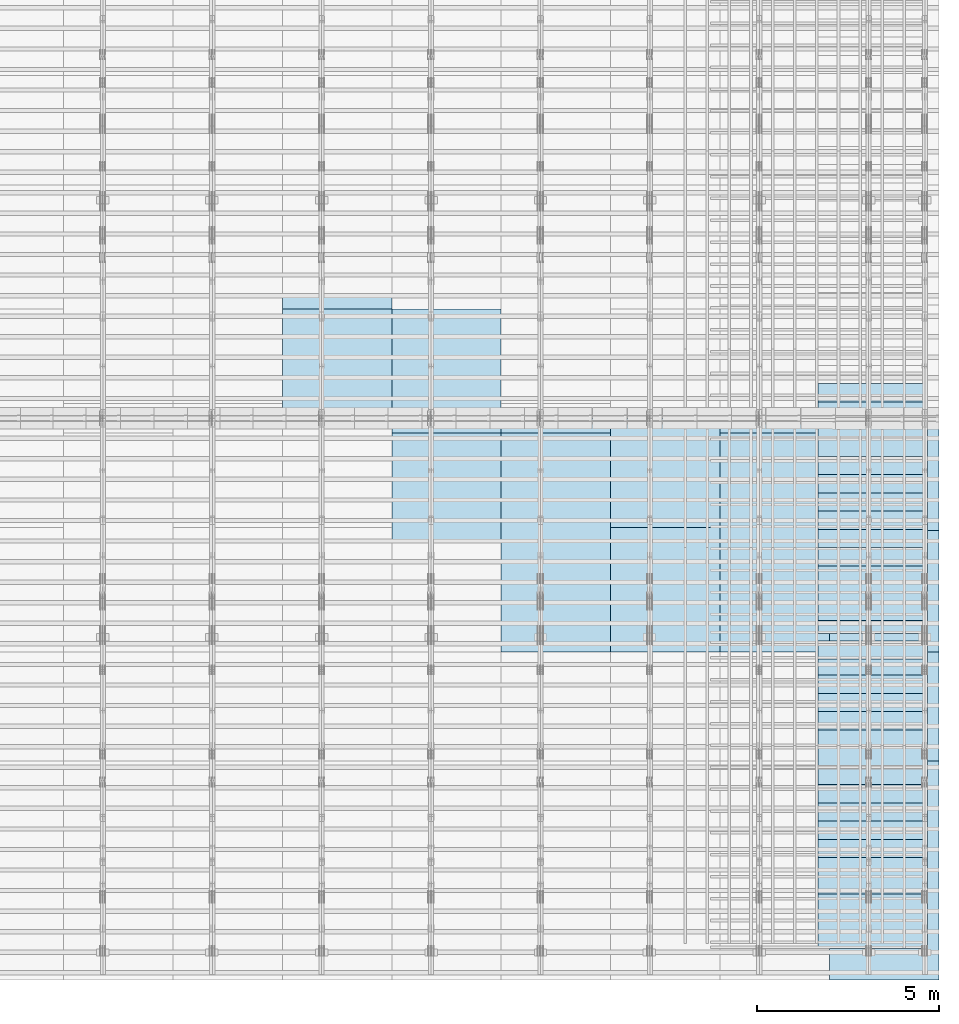
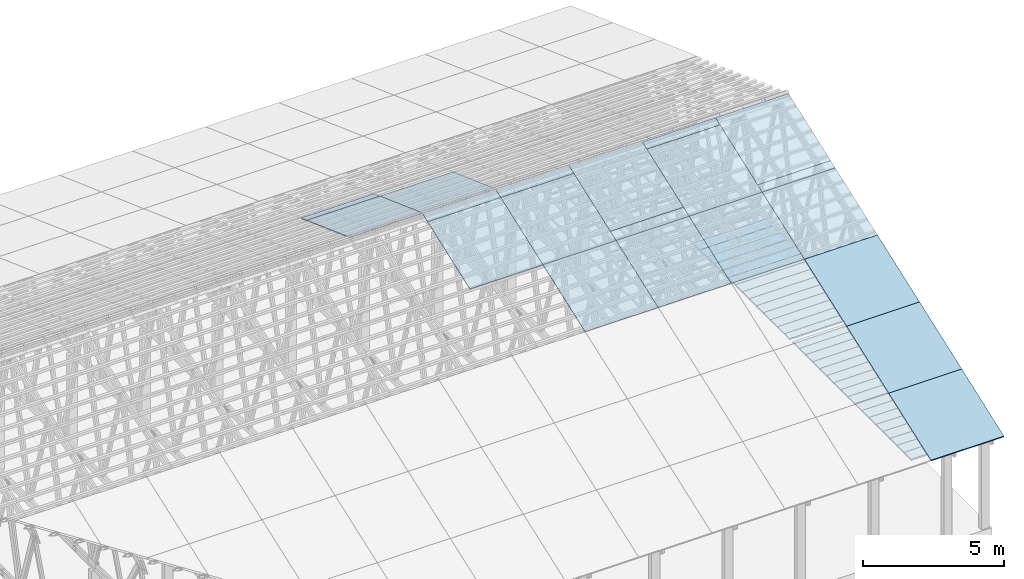
# One storey, part 9 of 189: 51 slabs, 51 elements without a shape of their own.
"""IFC2X3 building model written with IfcOpenShell, lengths in millimetres."""

import ifcopenshell
import ifcopenshell.guid

model = None  # the IFC model being written
_history = None  # IfcOwnerHistory: only IFC2X3 demands one
_inside = {}  # id of a spatial element -> (the spatial element, [elements in it])
_under = {}  # id of a project, library or spatial element -> (it, [spatial elements below it])
_declared = {}  # id of a project -> (the project, [libraries it declares])
_typed = {}  # id of a type object -> (the type object, [elements of that type])
_made_of = {}  # id of a material, layer set ... -> (it, [elements and type objects made of it])


def new_model(schema):
    """Start an empty IFC model of exactly this schema.

    Asked for "IFC4X3", IfcOpenShell would pick the latest addendum, in which some entities
    have other attributes; the version numbers below select the first issue.
    IFC2X3 requires an IfcOwnerHistory on every rooted entity: one is made here for all.
    """
    global model, _history
    if schema == "IFC4X3":
        model = ifcopenshell.file(schema_version=(4, 3, 0, 0))
    else:
        model = ifcopenshell.file(schema=schema)
    _inside.clear()
    _under.clear()
    _declared.clear()
    _typed.clear()
    _made_of.clear()
    _history = None
    if model.schema == "IFC2X3":
        org = make("IfcOrganization", Name="unknown")
        user = make(
            "IfcPersonAndOrganization",
            ThePerson=make("IfcPerson", FamilyName="unknown"),
            TheOrganization=org,
        )
        app = make(
            "IfcApplication",
            ApplicationDeveloper=org,
            Version="unknown",
            ApplicationFullName="unknown",
            ApplicationIdentifier="unknown",
        )
        _history = make(
            "IfcOwnerHistory",
            OwningUser=user,
            OwningApplication=app,
            ChangeAction="ADDED",
            CreationDate=0,
        )
    return model


def make(cls, **values):
    """One entity of the class cls with the attributes given. An attribute that is None is left unset."""
    return model.create_entity(
        cls, **{name: value for name, value in values.items() if value is not None}
    )


def entity(cls, *values):
    """Any entity or typed value of the class cls, its attributes in the order of the schema. None: left unset."""
    e = model.create_entity(cls)
    for i, value in enumerate(values):
        if value is not None:
            e[i] = value
    return e


def rooted(cls, **values):
    """An entity with a GlobalId (a new one), such as an element, a storey or a relation."""
    return make(cls, GlobalId=ifcopenshell.guid.new(), OwnerHistory=_history, **values)


def si_unit(unit_type, name, prefix=None):
    """IfcSIUnit, for example si_unit("LENGTHUNIT", "METRE", prefix="MILLI")."""
    return make("IfcSIUnit", UnitType=unit_type, Prefix=prefix, Name=name)


def converted_unit(unit_type, name, factor, base, dimensions=None, offset=None):
    """IfcConversionBasedUnit, such as the inch: factor (a typed value) times the base unit."""
    return make(
        "IfcConversionBasedUnit"
        if offset is None
        else "IfcConversionBasedUnitWithOffset",
        ConversionOffset=offset,
        Dimensions=None
        if dimensions is None
        else entity("IfcDimensionalExponents", *dimensions),
        UnitType=unit_type,
        Name=name,
        ConversionFactor=make(
            "IfcMeasureWithUnit", ValueComponent=factor, UnitComponent=base
        ),
    )


def derived_unit(unit_type, elements):
    """IfcDerivedUnit: a product of units, each with its exponent."""
    return make(
        "IfcDerivedUnit",
        Elements=[
            make("IfcDerivedUnitElement", Unit=unit, Exponent=power)
            for unit, power in elements
        ],
        UnitType=unit_type,
    )


def assignment(units):
    """IfcUnitAssignment: the units of a project."""
    return None if units is None else make("IfcUnitAssignment", Units=units)


def point(xyz):
    """IfcCartesianPoint."""
    return None if xyz is None else make("IfcCartesianPoint", Coordinates=xyz)


def direction(xyz):
    """IfcDirection."""
    return None if xyz is None else make("IfcDirection", DirectionRatios=xyz)


def frame(location, z_axis=None, x_axis=None):
    """IfcAxis2Placement3D, a coordinate frame: its origin and axes. An axis left out is left unset."""
    return make(
        "IfcAxis2Placement3D",
        Location=point(location),
        Axis=direction(z_axis),
        RefDirection=direction(x_axis),
    )


def frame_2d(location, x_axis=None):
    """IfcAxis2Placement2D, a coordinate frame in the plane: its origin and x axis."""
    return make(
        "IfcAxis2Placement2D", Location=point(location), RefDirection=direction(x_axis)
    )


def origin():
    """The frame at (0, 0, 0) with its axes left unset."""
    return frame((0.0, 0.0, 0.0))


def origin_2d_with_axis():
    """The frame at (0, 0) in the plane with the x axis (1, 0) written out."""
    return frame_2d((0.0, 0.0), x_axis=(1.0, 0.0))


def place(relative_to, where):
    """IfcLocalPlacement: puts the frame where relative to a parent placement (None: the world)."""
    return make(
        "IfcLocalPlacement", PlacementRelTo=relative_to, RelativePlacement=where
    )


def context(
    kind, dimensions, precision=None, world=None, true_north=None, identifier=None
):
    """IfcGeometricRepresentationContext, for example the 3D "Model" context."""
    return make(
        "IfcGeometricRepresentationContext",
        ContextIdentifier=identifier,
        ContextType=kind,
        CoordinateSpaceDimension=dimensions,
        Precision=precision,
        WorldCoordinateSystem=world,
        TrueNorth=true_north,
    )


def subcontext(parent, identifier, kind, view, scale=None):
    """IfcGeometricRepresentationSubContext, for example "Body" below "Model"."""
    return make(
        "IfcGeometricRepresentationSubContext",
        ContextIdentifier=identifier,
        ContextType=kind,
        ParentContext=parent,
        TargetScale=scale,
        TargetView=view,
    )


def project(units=None, contexts=None):
    """IfcProject with its units and contexts."""
    return rooted(
        "IfcProject",
        Name="project",
        RepresentationContexts=contexts,
        UnitsInContext=assignment(units),
    )


def spatial(cls, under=None, at=None, **own):
    """A site, building, storey or space (cls), placed at a placement, below another one or the project."""
    s = rooted(cls, ObjectPlacement=at, **own)
    if under is not None:
        _under.setdefault(under.id(), (under, []))[1].append(s)
    return s


def profile(cls, at=None, kind="AREA", **sizes):
    """A parametric profile (cls). Its sizes go by their IFC names, for example OverallWidth=200.0."""
    return make(cls, ProfileType=kind, Position=at, **sizes)


def rectangle(**sizes):
    """IfcRectangleProfileDef."""
    return profile("IfcRectangleProfileDef", **sizes)


def extrude(swept, where, along, depth):
    """IfcExtrudedAreaSolid: the profile swept, set in the frame where, extruded along a direction by depth."""
    return make(
        "IfcExtrudedAreaSolid",
        SweptArea=swept,
        Position=where,
        ExtrudedDirection=direction(along),
        Depth=depth,
    )


def shape(context_of_items, identifier, shape_type, items):
    """IfcShapeRepresentation: the items that make up one representation, for example the "Body"."""
    return make(
        "IfcShapeRepresentation",
        ContextOfItems=context_of_items,
        RepresentationIdentifier=identifier,
        RepresentationType=shape_type,
        Items=items,
    )


def material(Name=None, Category=None):
    """IfcMaterial."""
    return make("IfcMaterial", Name=Name, Category=Category)


def layer(
    of_material, thickness, ventilated=None, Name=None, Category=None, Priority=None
):
    """IfcMaterialLayer: one layer of a wall or slab, of a material (None: an air gap)."""
    return make(
        "IfcMaterialLayer",
        Material=of_material,
        LayerThickness=thickness,
        IsVentilated=ventilated,
        Name=Name,
        Category=Category,
        Priority=Priority,
    )


def layer_set(layers, Name=None):
    """IfcMaterialLayerSet."""
    return make("IfcMaterialLayerSet", MaterialLayers=layers, LayerSetName=Name)


def made_of(thing, what):
    """Note that an element or type object is made of a material, layer set ...; save() writes the relation."""
    if what is not None:
        _made_of.setdefault(what.id(), (what, []))[1].append(thing)
    return thing


def element(
    cls,
    number,
    at=None,
    inside=None,
    cuts=None,
    type_object=None,
    material=None,
    context=None,
    identifier="Body",
    shape_type=None,
    held_by="IfcProductDefinitionShape",
    body=None,
    shapes=None,
    **own,
):
    """One element of the class cls, such as IfcWall. Its Tag is "e" and its number.

    at: its placement. inside: the storey or other place that contains it. cuts: it is an
    opening in that element (IfcRelVoidsElement). A single representation is given by context,
    identifier, shape_type and body (its items); several are given by shapes. held_by: the class
    of the entity that holds the representations. save() writes the other relations.
    """
    e = rooted(cls, Tag="e%d" % number, ObjectPlacement=at, **own)
    if body is not None:
        shapes = [shape(context, identifier, shape_type, body)]
    if shapes is not None:
        e.Representation = make(held_by, Representations=shapes)
    if inside is not None:
        _inside.setdefault(inside.id(), (inside, []))[1].append(e)
    if cuts is not None:
        rooted(
            "IfcRelVoidsElement", RelatingBuildingElement=cuts, RelatedOpeningElement=e
        )
    if type_object is not None:
        _typed.setdefault(type_object.id(), (type_object, []))[1].append(e)
    return made_of(e, material)


def aggregate(whole, parts):
    """IfcRelAggregates: a whole, such as a stair, and the parts it consists of."""
    return rooted("IfcRelAggregates", RelatingObject=whole, RelatedObjects=parts)


def save(model, path):
    """Write the relations noted so far, then the file.

    IfcRelAggregates (storeys below a building ...), IfcRelContainedInSpatialStructure (elements
    in a storey), IfcRelDefinesByType, IfcRelAssociatesMaterial and IfcRelDeclares: one each for
    every whole, place, type object, material and project.
    """
    for whole, parts in _under.values():
        aggregate(whole, parts)
    for where, things in _inside.values():
        rooted(
            "IfcRelContainedInSpatialStructure",
            RelatedElements=things,
            RelatingStructure=where,
        )
    for kind, things in _typed.values():
        rooted("IfcRelDefinesByType", RelatedObjects=things, RelatingType=kind)
    for what, things in _made_of.values():
        rooted("IfcRelAssociatesMaterial", RelatedObjects=things, RelatingMaterial=what)
    for by, libraries in _declared.values():
        rooted("IfcRelDeclares", RelatingContext=by, RelatedDefinitions=libraries)
    model.write(path)


model = new_model("IFC2X3")

# Units and contexts
model_context = context("Model", 3, precision=0.01, world=origin(), true_north=direction((6.12303176911189e-17, 1.0)))
body_context = subcontext(model_context, "Body", "Model", "MODEL_VIEW")
ifc_project = project(units=[si_unit("LENGTHUNIT", "METRE", prefix="MILLI"), si_unit("AREAUNIT", "SQUARE_METRE"), si_unit("VOLUMEUNIT", "CUBIC_METRE"), converted_unit("PLANEANGLEUNIT", "DEGREE", entity("IfcRatioMeasure", 0.0174532925199433), si_unit("PLANEANGLEUNIT", "RADIAN"), dimensions=[0, 0, 0, 0, 0, 0, 0]), si_unit("MASSUNIT", "GRAM", prefix="KILO"), derived_unit("MASSDENSITYUNIT", [(si_unit("MASSUNIT", "GRAM", prefix="KILO"), 1), (si_unit("LENGTHUNIT", "METRE"), -3)]), si_unit("TIMEUNIT", "SECOND"), si_unit("FREQUENCYUNIT", "HERTZ"), si_unit("THERMODYNAMICTEMPERATUREUNIT", "DEGREE_CELSIUS"), derived_unit("THERMALTRANSMITTANCEUNIT", [(si_unit("MASSUNIT", "GRAM", prefix="KILO"), 1), (si_unit("THERMODYNAMICTEMPERATUREUNIT", "KELVIN"), -1), (si_unit("TIMEUNIT", "SECOND"), -3)]), derived_unit("VOLUMETRICFLOWRATEUNIT", [(si_unit("LENGTHUNIT", "METRE"), 3), (si_unit("TIMEUNIT", "SECOND"), -1)]), si_unit("ELECTRICCURRENTUNIT", "AMPERE"), si_unit("ELECTRICVOLTAGEUNIT", "VOLT"), si_unit("POWERUNIT", "WATT"), si_unit("FORCEUNIT", "NEWTON"), si_unit("ILLUMINANCEUNIT", "LUX"), si_unit("LUMINOUSFLUXUNIT", "LUMEN"), si_unit("LUMINOUSINTENSITYUNIT", "CANDELA"), derived_unit("USERDEFINED", [(si_unit("MASSUNIT", "GRAM", prefix="KILO"), -1), (si_unit("LENGTHUNIT", "METRE"), -2), (si_unit("TIMEUNIT", "SECOND"), 3), (si_unit("LUMINOUSFLUXUNIT", "LUMEN"), 1)]), derived_unit("LINEARVELOCITYUNIT", [(si_unit("LENGTHUNIT", "METRE"), 1), (si_unit("TIMEUNIT", "SECOND"), -1)]), si_unit("PRESSUREUNIT", "PASCAL"), derived_unit("USERDEFINED", [(si_unit("LENGTHUNIT", "METRE"), -2), (si_unit("MASSUNIT", "GRAM", prefix="KILO"), 1), (si_unit("TIMEUNIT", "SECOND"), -2)])], contexts=[model_context])

# Site, building, storey
site_placement = place(None, origin())
site = spatial("IfcSite", under=ifc_project, at=site_placement, CompositionType="ELEMENT")
building_placement = place(site_placement, origin())
building = spatial("IfcBuilding", under=site, at=building_placement, CompositionType="ELEMENT")
storey_placement = place(building_placement, origin())
storey = spatial("IfcBuildingStorey", under=building, at=storey_placement, Name="Default", CompositionType="ELEMENT", Elevation=0.0)

# Roof, slab
roof_1_placement = place(storey_placement, frame((47153.4200853154, -652.222549250825, 238.115215731819)))
roof_1 = element("IfcRoof", 1, at=roof_1_placement, inside=storey, ShapeType="NOTDEFINED")
ifc_material_1 = material()
ifc_layer_1 = layer(ifc_material_1, 40.0)
ifc_layer_set_1 = layer_set([ifc_layer_1])
slab_1_placement = place(roof_1_placement, origin())
slab_1 = element("IfcSlab", 2, at=slab_1_placement, material=ifc_layer_set_1, PredefinedType="ROOF", context=body_context, shape_type="SweptSolid", body=[
    extrude(rectangle(XDim=3192.53331742773, YDim=2999.99999999999, at=frame_2d((0.0, -3.41060513164848e-13), x_axis=(0.0, -1.0))), frame((1500.0, 1500.0, 545.955351399302), z_axis=(0.0, -0.342020143325668, 0.939692620785909), x_axis=(1.0, 0.0, 0.0)), (0.0, 0.342020143325668, 0.939692620785909), 42.5671108990364),
])
aggregate(roof_1, [slab_1])

roof_2_placement = place(building_placement, frame((47153.4200853155, 2347.77745074917, 1330.02591853042)))
roof_2 = element("IfcRoof", 3, at=roof_2_placement, inside=storey, ShapeType="NOTDEFINED")
slab_2_placement = place(roof_2_placement, origin())
slab_2 = element("IfcSlab", 4, at=slab_2_placement, material=ifc_layer_set_1, PredefinedType="ROOF", context=body_context, shape_type="SweptSolid", body=[
    extrude(rectangle(XDim=3192.53331742773, YDim=2999.99999999999, at=frame_2d((0.0, -1.13686837721616e-13), x_axis=(0.0, -1.0))), frame((1500.0, 1500.0, 545.955351399302), z_axis=(0.0, -0.342020143325668, 0.939692620785909), x_axis=(1.0, 0.0, 0.0)), (0.0, 0.342020143325668, 0.939692620785909), 42.5671108990353),
])
aggregate(roof_2, [slab_2])

roof_3_placement = place(building_placement, frame((47153.4200853155, 5347.77745074918, 2421.93662132902)))
roof_3 = element("IfcRoof", 5, at=roof_3_placement, inside=storey, ShapeType="NOTDEFINED")
slab_3_placement = place(roof_3_placement, origin())
slab_3 = element("IfcSlab", 6, at=slab_3_placement, material=ifc_layer_set_1, PredefinedType="ROOF", context=body_context, shape_type="SweptSolid", body=[
    extrude(rectangle(XDim=3192.53331742773, YDim=2999.99999999999, at=frame_2d((0.0, 0.0), x_axis=(0.0, -1.0))), frame((1500.0, 1500.0, 545.955351399302), z_axis=(0.0, -0.342020143325668, 0.939692620785909), x_axis=(1.0, 0.0, 0.0)), (0.0, 0.342020143325668, 0.939692620785909), 42.5671108990355),
])
aggregate(roof_3, [slab_3])

roof_4_placement = place(building_placement, frame((47153.4200853155, 8347.77745074918, 3513.84732412761)))
roof_4 = element("IfcRoof", 7, at=roof_4_placement, inside=storey, ShapeType="NOTDEFINED")
slab_4_placement = place(roof_4_placement, origin())
slab_4 = element("IfcSlab", 8, at=slab_4_placement, material=ifc_layer_set_1, PredefinedType="ROOF", context=body_context, shape_type="SweptSolid", body=[
    extrude(rectangle(XDim=3192.53331742773, YDim=2999.99999999999, at=frame_2d((0.0, 0.0), x_axis=(0.0, -1.0))), frame((1500.0, 1500.0, 545.955351399301), z_axis=(0.0, -0.342020143325668, 0.939692620785909), x_axis=(1.0, 0.0, 0.0)), (0.0, 0.342020143325668, 0.939692620785909), 42.5671108990366),
])
aggregate(roof_4, [slab_4])

roof_5_placement = place(building_placement, frame((47153.4200853155, 11347.7774507492, 4605.75802692621)))
roof_5 = element("IfcRoof", 9, at=roof_5_placement, inside=storey, ShapeType="NOTDEFINED")
slab_5_placement = place(roof_5_placement, origin())
slab_5 = element("IfcSlab", 10, at=slab_5_placement, material=ifc_layer_set_1, PredefinedType="ROOF", context=body_context, shape_type="SweptSolid", body=[
    extrude(rectangle(XDim=3192.53331742773, YDim=2999.99999999999, at=frame_2d((0.0, 0.0), x_axis=(0.0, -1.0))), frame((1500.0, 1500.0, 545.955351399303), z_axis=(0.0, -0.342020143325669, 0.939692620785908), x_axis=(1.0, 0.0, 0.0)), (0.0, 0.342020143325669, 0.939692620785908), 42.5671108990361),
])
aggregate(roof_5, [slab_5])

roof_6_placement = place(building_placement, frame((47153.4200853155, 11670.1261710963, 4723.08336618636)))
roof_6 = element("IfcRoof", 11, at=roof_6_placement, inside=storey, ShapeType="NOTDEFINED")
slab_6_placement = place(roof_6_placement, origin())
slab_6 = element("IfcSlab", 12, at=slab_6_placement, material=ifc_layer_set_1, PredefinedType="ROOF", context=body_context, shape_type="SweptSolid", body=[
    extrude(rectangle(XDim=3192.53331742773, YDim=2999.99999999999, at=frame_2d((0.0, 0.0), x_axis=(0.0, -1.0))), frame((1500.0, 1500.0, 545.955351399303), z_axis=(0.0, -0.342020143325669, 0.939692620785908), x_axis=(1.0, 0.0, 0.0)), (0.0, 0.342020143325669, 0.939692620785908), 42.5671108990372),
])
aggregate(roof_6, [slab_6])

roof_7_placement = place(storey_placement, frame((44153.4200853155, 8347.77745074919, 3513.84732412761)))
roof_7 = element("IfcRoof", 13, at=roof_7_placement, inside=storey, ShapeType="NOTDEFINED")
slab_7_placement = place(roof_7_placement, origin())
slab_7 = element("IfcSlab", 14, at=slab_7_placement, material=ifc_layer_set_1, PredefinedType="ROOF", context=body_context, shape_type="SweptSolid", body=[
    extrude(rectangle(XDim=3192.53331742773, YDim=2999.99999999999, at=frame_2d((0.0, 0.0), x_axis=(0.0, -1.0))), frame((1500.0, 1500.0, 545.955351399301), z_axis=(0.0, -0.342020143325668, 0.939692620785909), x_axis=(1.0, 0.0, 0.0)), (0.0, 0.342020143325668, 0.939692620785909), 42.5671108990366),
])
aggregate(roof_7, [slab_7])

roof_8_placement = place(storey_placement, frame((44153.4200853155, 11347.7774507492, 4605.75802692621)))
roof_8 = element("IfcRoof", 15, at=roof_8_placement, inside=storey, ShapeType="NOTDEFINED")
slab_8_placement = place(roof_8_placement, origin())
slab_8 = element("IfcSlab", 16, at=slab_8_placement, material=ifc_layer_set_1, PredefinedType="ROOF", context=body_context, shape_type="SweptSolid", body=[
    extrude(rectangle(XDim=3192.53331742773, YDim=2999.99999999999, at=frame_2d((0.0, 0.0), x_axis=(0.0, -1.0))), frame((1500.0, 1500.0, 545.955351399303), z_axis=(0.0, -0.342020143325669, 0.939692620785908), x_axis=(1.0, 0.0, 0.0)), (0.0, 0.342020143325669, 0.939692620785908), 42.5671108990361),
])
aggregate(roof_8, [slab_8])

roof_9_placement = place(storey_placement, frame((44153.4200853155, 11670.1261710963, 4723.08336618635)))
roof_9 = element("IfcRoof", 17, at=roof_9_placement, inside=storey, ShapeType="NOTDEFINED")
slab_9_placement = place(roof_9_placement, origin())
slab_9 = element("IfcSlab", 18, at=slab_9_placement, material=ifc_layer_set_1, PredefinedType="ROOF", context=body_context, shape_type="SweptSolid", body=[
    extrude(rectangle(XDim=3192.53331742773, YDim=2999.99999999999, at=frame_2d((0.0, 0.0), x_axis=(0.0, -1.0))), frame((1500.0, 1500.0, 545.955351399303), z_axis=(0.0, -0.342020143325669, 0.939692620785908), x_axis=(1.0, 0.0, 0.0)), (0.0, 0.342020143325669, 0.939692620785908), 42.5671108990372),
])
aggregate(roof_9, [slab_9])

roof_10_placement = place(storey_placement, frame((41153.4200853155, 8347.7774507492, 3513.84732412761)))
roof_10 = element("IfcRoof", 19, at=roof_10_placement, inside=storey, ShapeType="NOTDEFINED")
slab_10_placement = place(roof_10_placement, origin())
slab_10 = element("IfcSlab", 20, at=slab_10_placement, material=ifc_layer_set_1, PredefinedType="ROOF", context=body_context, shape_type="SweptSolid", body=[
    extrude(rectangle(XDim=3192.53331742773, YDim=2999.99999999999, at=frame_2d((0.0, 0.0), x_axis=(0.0, -1.0))), frame((1500.0, 1500.0, 545.955351399301), z_axis=(0.0, -0.342020143325668, 0.939692620785909), x_axis=(1.0, 0.0, 0.0)), (0.0, 0.342020143325668, 0.939692620785909), 42.5671108990366),
])
aggregate(roof_10, [slab_10])

roof_11_placement = place(storey_placement, frame((41153.4200853155, 11347.7774507492, 4605.75802692621)))
roof_11 = element("IfcRoof", 21, at=roof_11_placement, inside=storey, ShapeType="NOTDEFINED")
slab_11_placement = place(roof_11_placement, origin())
slab_11 = element("IfcSlab", 22, at=slab_11_placement, material=ifc_layer_set_1, PredefinedType="ROOF", context=body_context, shape_type="SweptSolid", body=[
    extrude(rectangle(XDim=3192.53331742773, YDim=2999.99999999999, at=frame_2d((0.0, 0.0), x_axis=(0.0, -1.0))), frame((1500.0, 1500.0, 545.955351399303), z_axis=(0.0, -0.342020143325669, 0.939692620785908), x_axis=(1.0, 0.0, 0.0)), (0.0, 0.342020143325669, 0.939692620785908), 42.5671108990361),
])
aggregate(roof_11, [slab_11])

roof_12_placement = place(storey_placement, frame((41153.4200853155, 11750.0000438631, 4752.15507836903)))
roof_12 = element("IfcRoof", 23, at=roof_12_placement, inside=storey, ShapeType="NOTDEFINED")
slab_12_placement = place(roof_12_placement, origin())
slab_12 = element("IfcSlab", 24, at=slab_12_placement, material=ifc_layer_set_1, PredefinedType="ROOF", context=body_context, shape_type="SweptSolid", body=[
    extrude(rectangle(XDim=3192.53331742773, YDim=2999.99999999999, at=frame_2d((0.0, 0.0), x_axis=(0.0, -1.0))), frame((1500.0, 1500.0, 545.955351399303), z_axis=(0.0, -0.342020143325669, 0.939692620785908), x_axis=(1.0, 0.0, 0.0)), (0.0, 0.342020143325669, 0.939692620785908), 42.5671108990361),
])
aggregate(roof_12, [slab_12])

roof_13_placement = place(storey_placement, frame((38153.4200853155, 8347.77745074921, 3513.84732412761)))
roof_13 = element("IfcRoof", 25, at=roof_13_placement, inside=storey, ShapeType="NOTDEFINED")
slab_13_placement = place(roof_13_placement, origin())
slab_13 = element("IfcSlab", 26, at=slab_13_placement, material=ifc_layer_set_1, PredefinedType="ROOF", context=body_context, shape_type="SweptSolid", body=[
    extrude(rectangle(XDim=3192.53331742773, YDim=2999.99999999999, at=frame_2d((0.0, 0.0), x_axis=(0.0, -1.0))), frame((1500.0, 1500.0, 545.955351399301), z_axis=(0.0, -0.342020143325668, 0.939692620785909), x_axis=(1.0, 0.0, 0.0)), (0.0, 0.342020143325668, 0.939692620785909), 42.5671108990366),
])
aggregate(roof_13, [slab_13])

roof_14_placement = place(storey_placement, frame((38153.4200853155, 11347.7774507492, 4605.75802692621)))
roof_14 = element("IfcRoof", 27, at=roof_14_placement, inside=storey, ShapeType="NOTDEFINED")
slab_14_placement = place(roof_14_placement, origin())
slab_14 = element("IfcSlab", 28, at=slab_14_placement, material=ifc_layer_set_1, PredefinedType="ROOF", context=body_context, shape_type="SweptSolid", body=[
    extrude(rectangle(XDim=3192.53331742773, YDim=2999.99999999999, at=frame_2d((0.0, 0.0), x_axis=(0.0, -1.0))), frame((1500.0, 1500.0, 545.955351399303), z_axis=(0.0, -0.342020143325669, 0.939692620785908), x_axis=(1.0, 0.0, 0.0)), (0.0, 0.342020143325669, 0.939692620785908), 42.5671108990361),
])
aggregate(roof_14, [slab_14])

roof_15_placement = place(storey_placement, frame((38153.4200853155, 11750.0000438631, 4752.15507836903)))
roof_15 = element("IfcRoof", 29, at=roof_15_placement, inside=storey, ShapeType="NOTDEFINED")
slab_15_placement = place(roof_15_placement, origin())
slab_15 = element("IfcSlab", 30, at=slab_15_placement, material=ifc_layer_set_1, PredefinedType="ROOF", context=body_context, shape_type="SweptSolid", body=[
    extrude(rectangle(XDim=3192.53331742773, YDim=2999.99999999999, at=frame_2d((0.0, 0.0), x_axis=(0.0, -1.0))), frame((1500.0, 1500.0, 545.955351399303), z_axis=(0.0, -0.342020143325669, 0.939692620785908), x_axis=(1.0, 0.0, 0.0)), (0.0, 0.342020143325669, 0.939692620785908), 42.5671108990361),
])
aggregate(roof_15, [slab_15])

roof_16_placement = place(storey_placement, frame((35153.4200853156, 11347.7774507492, 4605.75802692621)))
roof_16 = element("IfcRoof", 31, at=roof_16_placement, inside=storey, ShapeType="NOTDEFINED")
slab_16_placement = place(roof_16_placement, origin())
slab_16 = element("IfcSlab", 32, at=slab_16_placement, material=ifc_layer_set_1, PredefinedType="ROOF", context=body_context, shape_type="SweptSolid", body=[
    extrude(rectangle(XDim=3192.53331742773, YDim=2999.99999999999, at=frame_2d((0.0, 0.0), x_axis=(0.0, -1.0))), frame((1500.0, 1500.0, 545.955351399303), z_axis=(0.0, -0.342020143325669, 0.939692620785908), x_axis=(1.0, 0.0, 0.0)), (0.0, 0.342020143325669, 0.939692620785908), 42.5671108990361),
])
aggregate(roof_16, [slab_16])

roof_17_placement = place(storey_placement, frame((35153.4200853156, 11750.0000438631, 4752.15507836903)))
roof_17 = element("IfcRoof", 33, at=roof_17_placement, inside=storey, ShapeType="NOTDEFINED")
slab_17_placement = place(roof_17_placement, origin())
slab_17 = element("IfcSlab", 34, at=slab_17_placement, material=ifc_layer_set_1, PredefinedType="ROOF", context=body_context, shape_type="SweptSolid", body=[
    extrude(rectangle(XDim=3192.53331742773, YDim=2999.99999999999, at=frame_2d((0.0, 0.0), x_axis=(0.0, -1.0))), frame((1500.0, 1500.0, 545.955351399303), z_axis=(0.0, -0.342020143325669, 0.939692620785908), x_axis=(1.0, 0.0, 0.0)), (0.0, 0.342020143325669, 0.939692620785908), 42.5671108990361),
])
aggregate(roof_17, [slab_17])

roof_18_placement = place(storey_placement, frame((35153.4200853156, 14750.0000438631, 4752.15507836903)))
roof_18 = element("IfcRoof", 35, at=roof_18_placement, inside=storey, ShapeType="NOTDEFINED")
slab_18_placement = place(roof_18_placement, origin())
slab_18 = element("IfcSlab", 36, at=slab_18_placement, material=ifc_layer_set_1, PredefinedType="ROOF", context=body_context, shape_type="SweptSolid", body=[
    extrude(rectangle(XDim=3192.53331742773, YDim=3000.0, at=frame_2d((2.1600499167107e-12, -1.13686837721616e-13), x_axis=(0.0, 1.0))), frame((1500.0, 1500.0, 545.955351399304), z_axis=(0.0, 0.342020143325669, 0.939692620785908), x_axis=(1.0, 0.0, 0.0)), (0.0, -0.342020143325669, 0.939692620785908), 42.5671108990361),
])
aggregate(roof_18, [slab_18])

roof_19_placement = place(storey_placement, frame((32153.4200853156, 15152.222636977, 4605.75802692621)))
roof_19 = element("IfcRoof", 37, at=roof_19_placement, inside=storey, ShapeType="NOTDEFINED")
slab_19_placement = place(roof_19_placement, origin())
slab_19 = element("IfcSlab", 38, at=slab_19_placement, material=ifc_layer_set_1, PredefinedType="ROOF", context=body_context, shape_type="SweptSolid", body=[
    extrude(rectangle(XDim=3192.53331742773, YDim=3000.0, at=frame_2d((2.1600499167107e-12, -1.13686837721616e-13), x_axis=(0.0, 1.0))), frame((1500.0, 1500.0, 545.955351399304), z_axis=(0.0, 0.342020143325669, 0.939692620785908), x_axis=(1.0, 0.0, 0.0)), (0.0, -0.342020143325669, 0.939692620785908), 42.5671108990361),
])
aggregate(roof_19, [slab_19])

roof_20_placement = place(storey_placement, frame((32153.4200853156, 14750.0000438631, 4752.15507836903)))
roof_20 = element("IfcRoof", 39, at=roof_20_placement, inside=storey, ShapeType="NOTDEFINED")
slab_20_placement = place(roof_20_placement, origin())
slab_20 = element("IfcSlab", 40, at=slab_20_placement, material=ifc_layer_set_1, PredefinedType="ROOF", context=body_context, shape_type="SweptSolid", body=[
    extrude(rectangle(XDim=3192.53331742773, YDim=3000.0, at=frame_2d((2.1600499167107e-12, -1.13686837721616e-13), x_axis=(0.0, 1.0))), frame((1500.0, 1500.0, 545.955351399304), z_axis=(0.0, 0.342020143325669, 0.939692620785908), x_axis=(1.0, 0.0, 0.0)), (0.0, -0.342020143325669, 0.939692620785908), 42.5671108990361),
])
aggregate(roof_20, [slab_20])

roof_21_placement = place(storey_placement, frame((46837.7477027694, 205.0, -150.0)))
roof_21 = element("IfcRoof", 41, at=roof_21_placement, inside=storey, ShapeType="NOTDEFINED")
ifc_material_2 = material(Name="NLRS_n7_isolatie MegaPlus_Kingspan")
ifc_layer_2 = layer(ifc_material_2, 60.0)
ifc_layer_set_2 = layer_set([ifc_layer_2])
slab_21_placement = place(roof_21_placement, origin())
slab_21 = element("IfcSlab", 42, at=slab_21_placement, material=ifc_layer_set_2, PredefinedType="ROOF", context=body_context, shape_type="SweptSolid", body=[
    extrude(rectangle(XDim=3000.00000000001, YDim=499.99999999999, at=origin_2d_with_axis()), frame((1500.0, 250.0, 0.0)), (0.0, 0.0, 1.0), 60.0),
])
aggregate(roof_21, [slab_21])

roof_22_placement = place(storey_placement, frame((46837.7477027694, 705.0, -150.0)))
roof_22 = element("IfcRoof", 43, at=roof_22_placement, inside=storey, ShapeType="NOTDEFINED")
slab_22_placement = place(roof_22_placement, origin())
slab_22 = element("IfcSlab", 44, at=slab_22_placement, material=ifc_layer_set_2, PredefinedType="ROOF", context=body_context, shape_type="SweptSolid", body=[
    extrude(rectangle(XDim=3000.00000000001, YDim=499.99999999999, at=origin_2d_with_axis()), frame((1500.0, 250.0, 0.0)), (0.0, 0.0, 1.0), 60.0),
])
aggregate(roof_22, [slab_22])

roof_23_placement = place(storey_placement, frame((46837.7477027694, 1205.0, -150.0)))
roof_23 = element("IfcRoof", 45, at=roof_23_placement, inside=storey, ShapeType="NOTDEFINED")
slab_23_placement = place(roof_23_placement, origin())
slab_23 = element("IfcSlab", 46, at=slab_23_placement, material=ifc_layer_set_2, PredefinedType="ROOF", context=body_context, shape_type="SweptSolid", body=[
    extrude(rectangle(XDim=3000.00000000001, YDim=499.99999999999, at=origin_2d_with_axis()), frame((1500.0, 250.0, 0.0)), (0.0, 0.0, 1.0), 60.0),
])
aggregate(roof_23, [slab_23])

roof_24_placement = place(storey_placement, frame((46837.7477027694, 1705.0, -150.0)))
roof_24 = element("IfcRoof", 47, at=roof_24_placement, inside=storey, ShapeType="NOTDEFINED")
slab_24_placement = place(roof_24_placement, origin())
slab_24 = element("IfcSlab", 48, at=slab_24_placement, material=ifc_layer_set_2, PredefinedType="ROOF", context=body_context, shape_type="SweptSolid", body=[
    extrude(rectangle(XDim=3000.00000000001, YDim=499.99999999999, at=origin_2d_with_axis()), frame((1500.0, 250.0, 0.0)), (0.0, 0.0, 1.0), 60.0),
])
aggregate(roof_24, [slab_24])

roof_25_placement = place(storey_placement, frame((46837.7477027694, 2205.0, -150.0)))
roof_25 = element("IfcRoof", 49, at=roof_25_placement, inside=storey, ShapeType="NOTDEFINED")
slab_25_placement = place(roof_25_placement, origin())
slab_25 = element("IfcSlab", 50, at=slab_25_placement, material=ifc_layer_set_2, PredefinedType="ROOF", context=body_context, shape_type="SweptSolid", body=[
    extrude(rectangle(XDim=3000.00000000001, YDim=499.99999999999, at=origin_2d_with_axis()), frame((1500.0, 250.0, 0.0)), (0.0, 0.0, 1.0), 60.0),
])
aggregate(roof_25, [slab_25])

roof_26_placement = place(storey_placement, frame((46837.7477027694, 2705.0, -150.0)))
roof_26 = element("IfcRoof", 51, at=roof_26_placement, inside=storey, ShapeType="NOTDEFINED")
slab_26_placement = place(roof_26_placement, origin())
slab_26 = element("IfcSlab", 52, at=slab_26_placement, material=ifc_layer_set_2, PredefinedType="ROOF", context=body_context, shape_type="SweptSolid", body=[
    extrude(rectangle(XDim=3000.00000000001, YDim=499.99999999999, at=origin_2d_with_axis()), frame((1500.0, 250.0, 0.0)), (0.0, 0.0, 1.0), 60.0),
])
aggregate(roof_26, [slab_26])

roof_27_placement = place(storey_placement, frame((46837.7477027694, 3205.0, -150.0)))
roof_27 = element("IfcRoof", 53, at=roof_27_placement, inside=storey, ShapeType="NOTDEFINED")
slab_27_placement = place(roof_27_placement, origin())
slab_27 = element("IfcSlab", 54, at=slab_27_placement, material=ifc_layer_set_2, PredefinedType="ROOF", context=body_context, shape_type="SweptSolid", body=[
    extrude(rectangle(XDim=3000.00000000001, YDim=499.99999999999, at=origin_2d_with_axis()), frame((1500.0, 250.0, 0.0)), (0.0, 0.0, 1.0), 60.0),
])
aggregate(roof_27, [slab_27])

roof_28_placement = place(storey_placement, frame((46837.7477027694, 3705.0, -150.0)))
roof_28 = element("IfcRoof", 55, at=roof_28_placement, inside=storey, ShapeType="NOTDEFINED")
slab_28_placement = place(roof_28_placement, origin())
slab_28 = element("IfcSlab", 56, at=slab_28_placement, material=ifc_layer_set_2, PredefinedType="ROOF", context=body_context, shape_type="SweptSolid", body=[
    extrude(rectangle(XDim=3000.00000000001, YDim=499.99999999999, at=origin_2d_with_axis()), frame((1500.0, 250.0, 0.0)), (0.0, 0.0, 1.0), 60.0),
])
aggregate(roof_28, [slab_28])

roof_29_placement = place(storey_placement, frame((46837.7477027694, 4205.0, -150.0)))
roof_29 = element("IfcRoof", 57, at=roof_29_placement, inside=storey, ShapeType="NOTDEFINED")
slab_29_placement = place(roof_29_placement, origin())
slab_29 = element("IfcSlab", 58, at=slab_29_placement, material=ifc_layer_set_2, PredefinedType="ROOF", context=body_context, shape_type="SweptSolid", body=[
    extrude(rectangle(XDim=3000.00000000001, YDim=499.99999999999, at=origin_2d_with_axis()), frame((1500.0, 250.0, 0.0)), (0.0, 0.0, 1.0), 60.0),
])
aggregate(roof_29, [slab_29])

roof_30_placement = place(storey_placement, frame((46837.7477027694, 4705.0, -150.0)))
roof_30 = element("IfcRoof", 59, at=roof_30_placement, inside=storey, ShapeType="NOTDEFINED")
slab_30_placement = place(roof_30_placement, origin())
slab_30 = element("IfcSlab", 60, at=slab_30_placement, material=ifc_layer_set_2, PredefinedType="ROOF", context=body_context, shape_type="SweptSolid", body=[
    extrude(rectangle(XDim=3000.00000000001, YDim=499.99999999999, at=origin_2d_with_axis()), frame((1500.0, 250.0, 0.0)), (0.0, 0.0, 1.0), 60.0),
])
aggregate(roof_30, [slab_30])

roof_31_placement = place(storey_placement, frame((46837.7477027694, 5205.0, -150.0)))
roof_31 = element("IfcRoof", 61, at=roof_31_placement, inside=storey, ShapeType="NOTDEFINED")
slab_31_placement = place(roof_31_placement, origin())
slab_31 = element("IfcSlab", 62, at=slab_31_placement, material=ifc_layer_set_2, PredefinedType="ROOF", context=body_context, shape_type="SweptSolid", body=[
    extrude(rectangle(XDim=3000.00000000001, YDim=499.99999999999, at=origin_2d_with_axis()), frame((1500.0, 250.0, 0.0)), (0.0, 0.0, 1.0), 60.0),
])
aggregate(roof_31, [slab_31])

roof_32_placement = place(storey_placement, frame((46837.7477027694, 5705.0, -150.0)))
roof_32 = element("IfcRoof", 63, at=roof_32_placement, inside=storey, ShapeType="NOTDEFINED")
slab_32_placement = place(roof_32_placement, origin())
slab_32 = element("IfcSlab", 64, at=slab_32_placement, material=ifc_layer_set_2, PredefinedType="ROOF", context=body_context, shape_type="SweptSolid", body=[
    extrude(rectangle(XDim=3000.00000000001, YDim=499.99999999999, at=origin_2d_with_axis()), frame((1500.0, 250.0, 0.0)), (0.0, 0.0, 1.0), 60.0),
])
aggregate(roof_32, [slab_32])

roof_33_placement = place(storey_placement, frame((46837.7477027694, 6205.0, -150.0)))
roof_33 = element("IfcRoof", 65, at=roof_33_placement, inside=storey, ShapeType="NOTDEFINED")
slab_33_placement = place(roof_33_placement, origin())
slab_33 = element("IfcSlab", 66, at=slab_33_placement, material=ifc_layer_set_2, PredefinedType="ROOF", context=body_context, shape_type="SweptSolid", body=[
    extrude(rectangle(XDim=3000.00000000001, YDim=499.99999999999, at=origin_2d_with_axis()), frame((1500.0, 250.0, 0.0)), (0.0, 0.0, 1.0), 60.0),
])
aggregate(roof_33, [slab_33])

roof_34_placement = place(storey_placement, frame((46837.7477027694, 6705.0, -150.0)))
roof_34 = element("IfcRoof", 67, at=roof_34_placement, inside=storey, ShapeType="NOTDEFINED")
slab_34_placement = place(roof_34_placement, origin())
slab_34 = element("IfcSlab", 68, at=slab_34_placement, material=ifc_layer_set_2, PredefinedType="ROOF", context=body_context, shape_type="SweptSolid", body=[
    extrude(rectangle(XDim=3000.00000000001, YDim=499.99999999999, at=origin_2d_with_axis()), frame((1500.0, 250.0, 0.0)), (0.0, 0.0, 1.0), 60.0),
])
aggregate(roof_34, [slab_34])

roof_35_placement = place(storey_placement, frame((46837.7477027694, 7205.0, -150.0)))
roof_35 = element("IfcRoof", 69, at=roof_35_placement, inside=storey, ShapeType="NOTDEFINED")
slab_35_placement = place(roof_35_placement, origin())
slab_35 = element("IfcSlab", 70, at=slab_35_placement, material=ifc_layer_set_2, PredefinedType="ROOF", context=body_context, shape_type="SweptSolid", body=[
    extrude(rectangle(XDim=3000.00000000001, YDim=499.99999999999, at=origin_2d_with_axis()), frame((1500.0, 250.0, 0.0)), (0.0, 0.0, 1.0), 60.0),
])
aggregate(roof_35, [slab_35])

roof_36_placement = place(storey_placement, frame((46837.7477027694, 7705.0, -150.0)))
roof_36 = element("IfcRoof", 71, at=roof_36_placement, inside=storey, ShapeType="NOTDEFINED")
slab_36_placement = place(roof_36_placement, origin())
slab_36 = element("IfcSlab", 72, at=slab_36_placement, material=ifc_layer_set_2, PredefinedType="ROOF", context=body_context, shape_type="SweptSolid", body=[
    extrude(rectangle(XDim=3000.00000000001, YDim=499.99999999999, at=origin_2d_with_axis()), frame((1500.0, 250.0, 0.0)), (0.0, 0.0, 1.0), 60.0),
])
aggregate(roof_36, [slab_36])

roof_37_placement = place(storey_placement, frame((46837.7477027694, 8150.0, -150.0)))
roof_37 = element("IfcRoof", 73, at=roof_37_placement, inside=storey, ShapeType="NOTDEFINED")
slab_37_placement = place(roof_37_placement, origin())
slab_37 = element("IfcSlab", 74, at=slab_37_placement, material=ifc_layer_set_2, PredefinedType="ROOF", context=body_context, shape_type="SweptSolid", body=[
    extrude(rectangle(XDim=3000.00000000001, YDim=499.99999999999, at=origin_2d_with_axis()), frame((1500.0, 250.0, 0.0)), (0.0, 0.0, 1.0), 60.0),
])
aggregate(roof_37, [slab_37])

roof_38_placement = place(storey_placement, frame((46837.7477027694, 8850.0, -150.0)))
roof_38 = element("IfcRoof", 75, at=roof_38_placement, inside=storey, ShapeType="NOTDEFINED")
slab_38_placement = place(roof_38_placement, origin())
slab_38 = element("IfcSlab", 76, at=slab_38_placement, material=ifc_layer_set_2, PredefinedType="ROOF", context=body_context, shape_type="SweptSolid", body=[
    extrude(rectangle(XDim=3000.00000000001, YDim=499.99999999999, at=origin_2d_with_axis()), frame((1500.0, 250.0, 0.0)), (0.0, 0.0, 1.0), 60.0),
])
aggregate(roof_38, [slab_38])

roof_39_placement = place(storey_placement, frame((46837.7477027695, 9205.0, -150.0)))
roof_39 = element("IfcRoof", 77, at=roof_39_placement, inside=storey, ShapeType="NOTDEFINED")
slab_39_placement = place(roof_39_placement, origin())
slab_39 = element("IfcSlab", 78, at=slab_39_placement, material=ifc_layer_set_2, PredefinedType="ROOF", context=body_context, shape_type="SweptSolid", body=[
    extrude(rectangle(XDim=3000.00000000001, YDim=499.99999999999, at=origin_2d_with_axis()), frame((1500.0, 250.0, 0.0)), (0.0, 0.0, 1.0), 60.0),
])
aggregate(roof_39, [slab_39])

roof_40_placement = place(storey_placement, frame((46837.7477027695, 9705.0, -150.0)))
roof_40 = element("IfcRoof", 79, at=roof_40_placement, inside=storey, ShapeType="NOTDEFINED")
slab_40_placement = place(roof_40_placement, origin())
slab_40 = element("IfcSlab", 80, at=slab_40_placement, material=ifc_layer_set_2, PredefinedType="ROOF", context=body_context, shape_type="SweptSolid", body=[
    extrude(rectangle(XDim=3000.00000000001, YDim=499.99999999999, at=origin_2d_with_axis()), frame((1500.0, 250.0, 0.0)), (0.0, 0.0, 1.0), 60.0),
])
aggregate(roof_40, [slab_40])

roof_41_placement = place(storey_placement, frame((46837.7477027695, 10205.0, -150.0)))
roof_41 = element("IfcRoof", 81, at=roof_41_placement, inside=storey, ShapeType="NOTDEFINED")
slab_41_placement = place(roof_41_placement, origin())
slab_41 = element("IfcSlab", 82, at=slab_41_placement, material=ifc_layer_set_2, PredefinedType="ROOF", context=body_context, shape_type="SweptSolid", body=[
    extrude(rectangle(XDim=3000.00000000001, YDim=499.99999999999, at=origin_2d_with_axis()), frame((1500.0, 250.0, 0.0)), (0.0, 0.0, 1.0), 60.0),
])
aggregate(roof_41, [slab_41])

roof_42_placement = place(storey_placement, frame((46837.7477027695, 10705.0, -150.0)))
roof_42 = element("IfcRoof", 83, at=roof_42_placement, inside=storey, ShapeType="NOTDEFINED")
slab_42_placement = place(roof_42_placement, origin())
slab_42 = element("IfcSlab", 84, at=slab_42_placement, material=ifc_layer_set_2, PredefinedType="ROOF", context=body_context, shape_type="SweptSolid", body=[
    extrude(rectangle(XDim=3000.00000000001, YDim=499.99999999999, at=origin_2d_with_axis()), frame((1500.0, 250.0, 0.0)), (0.0, 0.0, 1.0), 60.0),
])
aggregate(roof_42, [slab_42])

roof_43_placement = place(storey_placement, frame((46837.7477027695, 11205.0, -150.0)))
roof_43 = element("IfcRoof", 85, at=roof_43_placement, inside=storey, ShapeType="NOTDEFINED")
slab_43_placement = place(roof_43_placement, origin())
slab_43 = element("IfcSlab", 86, at=slab_43_placement, material=ifc_layer_set_2, PredefinedType="ROOF", context=body_context, shape_type="SweptSolid", body=[
    extrude(rectangle(XDim=3000.00000000001, YDim=499.99999999999, at=origin_2d_with_axis()), frame((1500.0, 250.0, 0.0)), (0.0, 0.0, 1.0), 60.0),
])
aggregate(roof_43, [slab_43])

roof_44_placement = place(storey_placement, frame((46837.7477027695, 11705.0, -150.0)))
roof_44 = element("IfcRoof", 87, at=roof_44_placement, inside=storey, ShapeType="NOTDEFINED")
slab_44_placement = place(roof_44_placement, origin())
slab_44 = element("IfcSlab", 88, at=slab_44_placement, material=ifc_layer_set_2, PredefinedType="ROOF", context=body_context, shape_type="SweptSolid", body=[
    extrude(rectangle(XDim=3000.00000000001, YDim=499.99999999999, at=origin_2d_with_axis()), frame((1500.0, 250.0, 0.0)), (0.0, 0.0, 1.0), 60.0),
])
aggregate(roof_44, [slab_44])

roof_45_placement = place(storey_placement, frame((46837.7477027695, 12205.0, -150.0)))
roof_45 = element("IfcRoof", 89, at=roof_45_placement, inside=storey, ShapeType="NOTDEFINED")
slab_45_placement = place(roof_45_placement, origin())
slab_45 = element("IfcSlab", 90, at=slab_45_placement, material=ifc_layer_set_2, PredefinedType="ROOF", context=body_context, shape_type="SweptSolid", body=[
    extrude(rectangle(XDim=3000.00000000001, YDim=499.99999999999, at=origin_2d_with_axis()), frame((1500.0, 250.0, 0.0)), (0.0, 0.0, 1.0), 60.0),
])
aggregate(roof_45, [slab_45])

roof_46_placement = place(storey_placement, frame((46837.7477027695, 12705.0, -150.0)))
roof_46 = element("IfcRoof", 91, at=roof_46_placement, inside=storey, ShapeType="NOTDEFINED")
slab_46_placement = place(roof_46_placement, origin())
slab_46 = element("IfcSlab", 92, at=slab_46_placement, material=ifc_layer_set_2, PredefinedType="ROOF", context=body_context, shape_type="SweptSolid", body=[
    extrude(rectangle(XDim=3000.00000000001, YDim=499.99999999999, at=origin_2d_with_axis()), frame((1500.0, 250.0, 0.0)), (0.0, 0.0, 1.0), 60.0),
])
aggregate(roof_46, [slab_46])

roof_47_placement = place(storey_placement, frame((46837.7477027695, 13205.0, -150.0)))
roof_47 = element("IfcRoof", 93, at=roof_47_placement, inside=storey, ShapeType="NOTDEFINED")
slab_47_placement = place(roof_47_placement, origin())
slab_47 = element("IfcSlab", 94, at=slab_47_placement, material=ifc_layer_set_2, PredefinedType="ROOF", context=body_context, shape_type="SweptSolid", body=[
    extrude(rectangle(XDim=3000.00000000001, YDim=499.99999999999, at=origin_2d_with_axis()), frame((1500.0, 250.0, 0.0)), (0.0, 0.0, 1.0), 60.0),
])
aggregate(roof_47, [slab_47])

roof_48_placement = place(storey_placement, frame((46837.7477027695, 13705.0, -150.0)))
roof_48 = element("IfcRoof", 95, at=roof_48_placement, inside=storey, ShapeType="NOTDEFINED")
slab_48_placement = place(roof_48_placement, origin())
slab_48 = element("IfcSlab", 96, at=slab_48_placement, material=ifc_layer_set_2, PredefinedType="ROOF", context=body_context, shape_type="SweptSolid", body=[
    extrude(rectangle(XDim=3000.00000000001, YDim=499.99999999999, at=origin_2d_with_axis()), frame((1500.0, 250.0, 0.0)), (0.0, 0.0, 1.0), 60.0),
])
aggregate(roof_48, [slab_48])

roof_49_placement = place(storey_placement, frame((46837.7477027695, 14205.0, -150.0)))
roof_49 = element("IfcRoof", 97, at=roof_49_placement, inside=storey, ShapeType="NOTDEFINED")
slab_49_placement = place(roof_49_placement, origin())
slab_49 = element("IfcSlab", 98, at=slab_49_placement, material=ifc_layer_set_2, PredefinedType="ROOF", context=body_context, shape_type="SweptSolid", body=[
    extrude(rectangle(XDim=3000.00000000001, YDim=499.99999999999, at=origin_2d_with_axis()), frame((1500.0, 250.0, 0.0)), (0.0, 0.0, 1.0), 60.0),
])
aggregate(roof_49, [slab_49])

roof_50_placement = place(storey_placement, frame((46837.7477027695, 14705.0, -150.0)))
roof_50 = element("IfcRoof", 99, at=roof_50_placement, inside=storey, ShapeType="NOTDEFINED")
slab_50_placement = place(roof_50_placement, origin())
slab_50 = element("IfcSlab", 100, at=slab_50_placement, material=ifc_layer_set_2, PredefinedType="ROOF", context=body_context, shape_type="SweptSolid", body=[
    extrude(rectangle(XDim=3000.00000000001, YDim=499.99999999999, at=origin_2d_with_axis()), frame((1500.0, 250.0, 0.0)), (0.0, 0.0, 1.0), 60.0),
])
aggregate(roof_50, [slab_50])

roof_51_placement = place(storey_placement, frame((46837.7477027695, 15205.0, -150.0)))
roof_51 = element("IfcRoof", 101, at=roof_51_placement, inside=storey, ShapeType="NOTDEFINED")
slab_51_placement = place(roof_51_placement, origin())
slab_51 = element("IfcSlab", 102, at=slab_51_placement, material=ifc_layer_set_2, PredefinedType="ROOF", context=body_context, shape_type="SweptSolid", body=[
    extrude(rectangle(XDim=3000.00000000001, YDim=499.99999999999, at=origin_2d_with_axis()), frame((1500.0, 250.0, 0.0)), (0.0, 0.0, 1.0), 60.0),
])
aggregate(roof_51, [slab_51])

save(model, "model.ifc")
